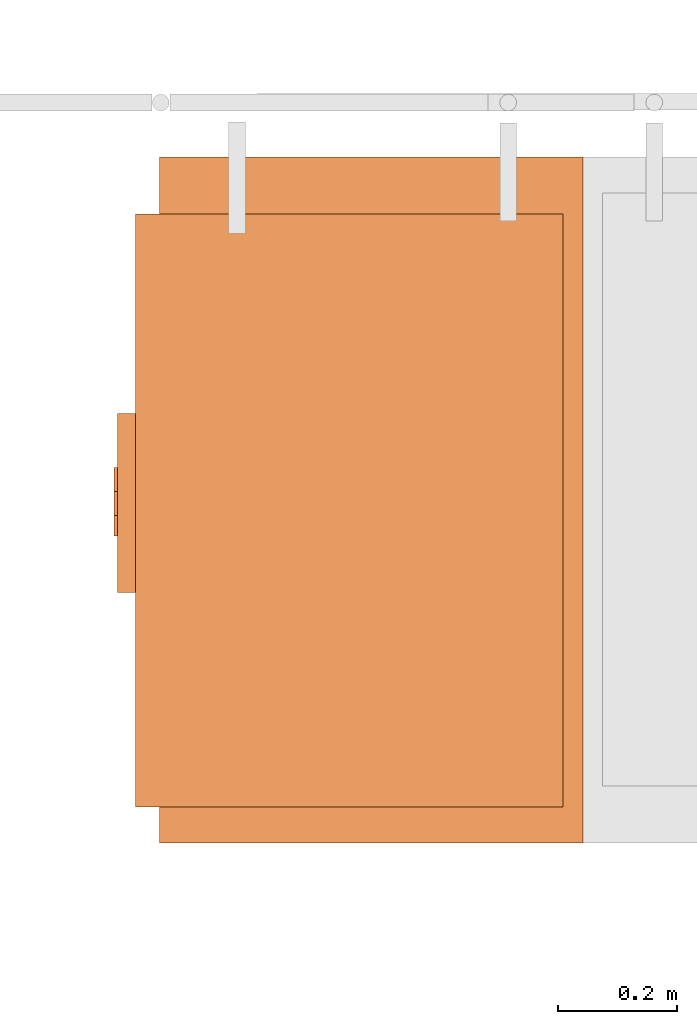
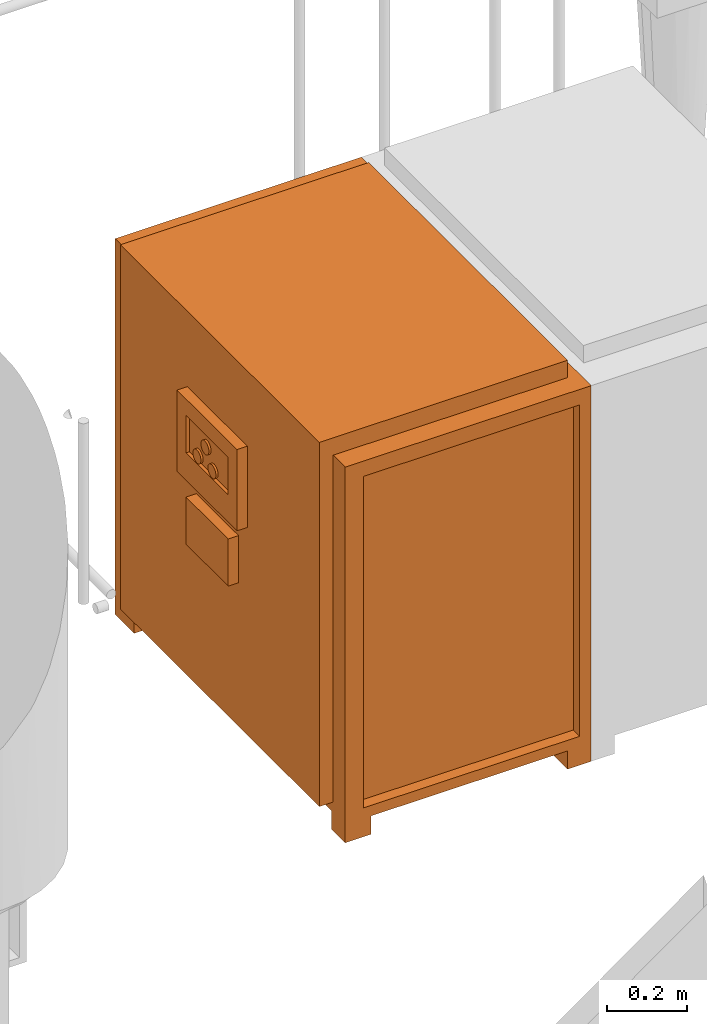
# One storey, part 327 of 331: 1 proxy.
"""IFC2X3 building model written with IfcOpenShell, lengths in millimetres."""

from ifc_helpers import new_model, entity, si_unit, converted_unit, derived_unit, direction, frame, origin, place, context, subcontext, project, spatial, faceted_brep, source, transform, mapped, material, material_list, type_object, type_shapes, element, save


model = new_model("IFC2X3")

# Units and contexts
model_context = context("Model", 3, precision=0.01, world=origin(), true_north=direction((6.12303176911189e-17, 1.0)))
body_context = subcontext(model_context, "Body", "Model", "MODEL_VIEW")
ifc_project = project(units=[si_unit("LENGTHUNIT", "METRE", prefix="MILLI"), si_unit("AREAUNIT", "SQUARE_METRE"), si_unit("VOLUMEUNIT", "CUBIC_METRE"), converted_unit("PLANEANGLEUNIT", "DEGREE", entity("IfcRatioMeasure", 0.0174532925199433), si_unit("PLANEANGLEUNIT", "RADIAN"), dimensions=[0, 0, 0, 0, 0, 0, 0]), si_unit("MASSUNIT", "GRAM", prefix="KILO"), derived_unit("MASSDENSITYUNIT", [(si_unit("MASSUNIT", "GRAM", prefix="KILO"), 1), (si_unit("LENGTHUNIT", "METRE"), -3)]), derived_unit("MOMENTOFINERTIAUNIT", [(si_unit("LENGTHUNIT", "METRE"), 4)]), si_unit("TIMEUNIT", "SECOND"), si_unit("FREQUENCYUNIT", "HERTZ"), si_unit("THERMODYNAMICTEMPERATUREUNIT", "DEGREE_CELSIUS"), derived_unit("THERMALTRANSMITTANCEUNIT", [(si_unit("MASSUNIT", "GRAM", prefix="KILO"), 1), (si_unit("THERMODYNAMICTEMPERATUREUNIT", "KELVIN"), -1), (si_unit("TIMEUNIT", "SECOND"), -3)]), derived_unit("VOLUMETRICFLOWRATEUNIT", [(si_unit("LENGTHUNIT", "METRE"), 3), (si_unit("TIMEUNIT", "SECOND"), -1)]), derived_unit("MASSFLOWRATEUNIT", [(si_unit("MASSUNIT", "GRAM", prefix="KILO"), 1), (si_unit("TIMEUNIT", "SECOND"), -1)]), derived_unit("ROTATIONALFREQUENCYUNIT", [(si_unit("TIMEUNIT", "SECOND"), -1)]), si_unit("ELECTRICCURRENTUNIT", "AMPERE"), si_unit("ELECTRICVOLTAGEUNIT", "VOLT"), si_unit("POWERUNIT", "WATT"), si_unit("FORCEUNIT", "NEWTON", prefix="KILO"), si_unit("ILLUMINANCEUNIT", "LUX"), si_unit("LUMINOUSFLUXUNIT", "LUMEN"), si_unit("LUMINOUSINTENSITYUNIT", "CANDELA"), derived_unit("USERDEFINED", [(si_unit("MASSUNIT", "GRAM", prefix="KILO"), -1), (si_unit("LENGTHUNIT", "METRE"), -2), (si_unit("TIMEUNIT", "SECOND"), 3), (si_unit("LUMINOUSFLUXUNIT", "LUMEN"), 1)]), derived_unit("LINEARVELOCITYUNIT", [(si_unit("LENGTHUNIT", "METRE"), 1), (si_unit("TIMEUNIT", "SECOND"), -1)]), si_unit("PRESSUREUNIT", "PASCAL"), derived_unit("USERDEFINED", [(si_unit("LENGTHUNIT", "METRE"), -2), (si_unit("MASSUNIT", "GRAM", prefix="KILO"), 1), (si_unit("TIMEUNIT", "SECOND"), -2)]), derived_unit("LINEARFORCEUNIT", [(si_unit("MASSUNIT", "GRAM", prefix="KILO"), 1), (si_unit("LENGTHUNIT", "METRE"), 1), (si_unit("TIMEUNIT", "SECOND"), -2), (si_unit("LENGTHUNIT", "METRE"), -1)]), derived_unit("PLANARFORCEUNIT", [(si_unit("MASSUNIT", "GRAM", prefix="KILO"), 1), (si_unit("LENGTHUNIT", "METRE"), 1), (si_unit("TIMEUNIT", "SECOND"), -2), (si_unit("LENGTHUNIT", "METRE"), -2)])], contexts=[model_context])

# Site, building, storey
site_placement = place(None, frame((0.0, -0.00077364408347762, 0.0)))
site = spatial("IfcSite", under=ifc_project, at=site_placement, CompositionType="ELEMENT")
building_placement = place(site_placement, origin())
building = spatial("IfcBuilding", under=site, at=building_placement, CompositionType="ELEMENT")
storey_placement = place(building_placement, origin())
storey = spatial("IfcBuildingStorey", under=building, at=storey_placement, CompositionType="ELEMENT", Elevation=0.0)

# Proxy
ifc_material_1 = material()
ifc_material_2 = material()
ifc_material_3 = material()
ifc_material_list = material_list([ifc_material_1, ifc_material_2, ifc_material_3])
building_element_proxy_type = type_object("IfcBuildingElementProxyType", Name="DC50:DC50", PredefinedType="NOTDEFINED", material=ifc_material_1)
shared_shape = source(origin(), body_context, "Body", "Brep", [
    faceted_brep([(-483.897349584665, 149.270597872865, 819.451035293873), (-483.897349584665, 145.128462249134, 822.629407745831), (-483.897349584665, 141.950089797176, 826.771543369562), (-483.897349584665, 139.952081347083, 831.595162467512), (-483.897349584665, 139.270597872864, 836.771543369562), (-483.897349584665, 139.952081347083, 841.947924271613), (-483.897349584665, 141.950089797176, 846.771543369562), (-483.897349584665, 145.128462249133, 850.913678993293), (-483.897349584665, 149.270597872864, 854.092051445251), (-483.897349584665, 154.094216970814, 856.090059895344), (-483.897349584665, 159.270597872864, 856.771543369562), (-483.897349584665, 164.446978774915, 856.090059895344), (-483.897349584665, 169.270597872864, 854.092051445251), (-483.897349584665, 173.412733496595, 850.913678993293), (-483.897349584665, 176.591105948553, 846.771543369562), (-483.897349584665, 178.589114398646, 841.947924271613), (-483.897349584665, 179.270597872864, 836.771543369562), (-483.897349584665, 178.589114398646, 831.595162467512), (-483.897349584665, 176.591105948553, 826.771543369562), (-483.897349584665, 173.412733496595, 822.629407745831), (-483.897349584665, 169.270597872865, 819.451035293873), (-483.897349584665, 164.446978774915, 817.453026843781), (-483.897349584665, 159.270597872865, 816.771543369562), (-483.897349584665, 154.094216970814, 817.453026843781), (-477.5, 164.446978774915, 856.090059895344), (-477.5, 159.270597872864, 856.771543369562), (-477.5, 154.094216970814, 856.090059895344), (-477.5, 149.270597872864, 854.092051445251), (-477.5, 145.128462249133, 850.913678993293), (-477.5, 141.950089797176, 846.771543369562), (-477.5, 139.952081347083, 841.947924271613), (-477.5, 139.270597872864, 836.771543369562), (-477.5, 139.952081347083, 831.595162467512), (-477.5, 141.950089797176, 826.771543369562), (-477.5, 145.128462249134, 822.629407745831), (-477.5, 149.270597872865, 819.451035293873), (-477.5, 154.094216970814, 817.453026843781), (-477.5, 159.270597872865, 816.771543369562), (-477.5, 164.446978774915, 817.453026843781), (-477.5, 169.270597872865, 819.451035293873), (-477.5, 173.412733496595, 822.629407745831), (-477.5, 176.591105948553, 826.771543369562), (-477.5, 178.589114398646, 831.595162467512), (-477.5, 179.270597872864, 836.771543369562), (-477.5, 178.589114398646, 841.947924271613), (-477.5, 176.591105948553, 846.771543369562), (-477.5, 173.412733496595, 850.913678993293), (-477.5, 169.270597872864, 854.092051445251)], [[[0, 1, 2, 3, 4, 5, 6, 7, 8, 9, 10, 11, 12, 13, 14, 15, 16, 17, 18, 19, 20, 21, 22, 23]], [[24, 25, 26, 27, 28, 29, 30, 31, 32, 33, 34, 35, 36, 37, 38, 39, 40, 41, 42, 43, 44, 45, 46, 47]], [[42, 17, 16, 43]], [[41, 18, 17, 42]], [[20, 19, 40, 39]], [[41, 40, 19, 18]], [[21, 20, 39, 38]], [[22, 21, 38, 37]], [[36, 23, 22, 37]], [[35, 0, 23, 36]], [[2, 1, 34, 33]], [[35, 34, 1, 0]], [[3, 2, 33, 32]], [[4, 3, 32, 31]], [[30, 5, 4, 31]], [[29, 6, 5, 30]], [[8, 7, 28, 27]], [[29, 28, 7, 6]], [[9, 8, 27, 26]], [[10, 9, 26, 25]], [[24, 11, 10, 25]], [[47, 12, 11, 24]], [[14, 13, 46, 45]], [[47, 46, 13, 12]], [[15, 14, 45, 44]], [[16, 15, 44, 43]]]),
    faceted_brep([(-483.897349584665, 224.270597872864, 819.451035293874), (-483.897349584665, 220.128462249133, 822.629407745831), (-483.897349584665, 216.950089797176, 826.771543369562), (-483.897349584665, 214.952081347083, 831.595162467512), (-483.897349584665, 214.270597872864, 836.771543369563), (-483.897349584665, 214.952081347083, 841.947924271613), (-483.897349584665, 216.950089797176, 846.771543369563), (-483.897349584665, 220.128462249133, 850.913678993294), (-483.897349584665, 224.270597872864, 854.092051445251), (-483.897349584665, 229.094216970814, 856.090059895344), (-483.897349584665, 234.270597872864, 856.771543369563), (-483.897349584665, 239.446978774915, 856.090059895344), (-483.897349584665, 244.270597872864, 854.092051445251), (-483.897349584665, 248.412733496595, 850.913678993294), (-483.897349584665, 251.591105948553, 846.771543369563), (-483.897349584665, 253.589114398646, 841.947924271613), (-483.897349584665, 254.270597872864, 836.771543369563), (-483.897349584665, 253.589114398646, 831.595162467512), (-483.897349584665, 251.591105948553, 826.771543369563), (-483.897349584665, 248.412733496595, 822.629407745832), (-483.897349584665, 244.270597872864, 819.451035293874), (-483.897349584665, 239.446978774915, 817.453026843781), (-483.897349584665, 234.270597872864, 816.771543369562), (-483.897349584665, 229.094216970814, 817.453026843781), (-477.5, 239.446978774915, 856.090059895344), (-477.5, 234.270597872864, 856.771543369563), (-477.5, 229.094216970814, 856.090059895344), (-477.5, 224.270597872864, 854.092051445251), (-477.5, 220.128462249133, 850.913678993294), (-477.5, 216.950089797176, 846.771543369563), (-477.5, 214.952081347083, 841.947924271613), (-477.5, 214.270597872864, 836.771543369562), (-477.5, 214.952081347083, 831.595162467512), (-477.5, 216.950089797176, 826.771543369562), (-477.5, 220.128462249133, 822.629407745831), (-477.5, 224.270597872864, 819.451035293874), (-477.5, 229.094216970814, 817.453026843781), (-477.5, 234.270597872864, 816.771543369562), (-477.5, 239.446978774915, 817.453026843781), (-477.5, 244.270597872864, 819.451035293874), (-477.5, 248.412733496595, 822.629407745832), (-477.5, 251.591105948553, 826.771543369563), (-477.5, 253.589114398646, 831.595162467512), (-477.5, 254.270597872864, 836.771543369563), (-477.5, 253.589114398646, 841.947924271613), (-477.5, 251.591105948553, 846.771543369563), (-477.5, 248.412733496595, 850.913678993294), (-477.5, 244.270597872864, 854.092051445251)], [[[0, 1, 2, 3, 4, 5, 6, 7, 8, 9, 10, 11, 12, 13, 14, 15, 16, 17, 18, 19, 20, 21, 22, 23]], [[24, 25, 26, 27, 28, 29, 30, 31, 32, 33, 34, 35, 36, 37, 38, 39, 40, 41, 42, 43, 44, 45, 46, 47]], [[42, 17, 16, 43]], [[41, 18, 17, 42]], [[20, 19, 40, 39]], [[41, 40, 19, 18]], [[21, 20, 39, 38]], [[22, 21, 38, 37]], [[36, 23, 22, 37]], [[35, 0, 23, 36]], [[2, 1, 34, 33]], [[35, 34, 1, 0]], [[3, 2, 33, 32]], [[4, 3, 32, 31]], [[30, 5, 4, 31]], [[29, 6, 5, 30]], [[8, 7, 28, 27]], [[29, 28, 7, 6]], [[9, 8, 27, 26]], [[10, 9, 26, 25]], [[24, 11, 10, 25]], [[47, 12, 11, 24]], [[14, 13, 46, 45]], [[47, 46, 13, 12]], [[15, 14, 45, 44]], [[16, 15, 44, 43]]]),
    faceted_brep([(-483.897349584665, 184.252601976697, 870.671734278311), (-483.897349584665, 180.110466352966, 873.850106730268), (-483.897349584665, 176.932093901008, 877.992242353999), (-483.897349584665, 174.934085450915, 882.815861451949), (-483.897349584665, 174.252601976696, 887.992242353999), (-483.897349584665, 174.934085450915, 893.16862325605), (-483.897349584665, 176.932093901008, 897.992242353999), (-483.897349584665, 180.110466352965, 902.13437797773), (-483.897349584665, 184.252601976696, 905.312750429688), (-483.897349584665, 189.076221074646, 907.310758879781), (-483.897349584665, 194.252601976696, 907.992242353999), (-483.897349584665, 199.428982878747, 907.310758879781), (-483.897349584665, 204.252601976696, 905.312750429688), (-483.897349584665, 208.394737600427, 902.13437797773), (-483.897349584665, 211.573110052385, 897.992242353999), (-483.897349584665, 213.571118502478, 893.16862325605), (-483.897349584665, 214.252601976696, 887.992242353999), (-483.897349584665, 213.571118502478, 882.815861451949), (-483.897349584665, 211.573110052385, 877.992242354), (-483.897349584665, 208.394737600427, 873.850106730269), (-483.897349584665, 204.252601976697, 870.671734278311), (-483.897349584665, 199.428982878747, 868.673725828218), (-483.897349584665, 194.252601976697, 867.992242353999), (-483.897349584665, 189.076221074646, 868.673725828218), (-477.5, 199.428982878747, 907.310758879781), (-477.5, 194.252601976696, 907.992242353999), (-477.5, 189.076221074646, 907.310758879781), (-477.5, 184.252601976696, 905.312750429688), (-477.5, 180.110466352965, 902.13437797773), (-477.5, 176.932093901008, 897.992242353999), (-477.5, 174.934085450915, 893.16862325605), (-477.5, 174.252601976696, 887.992242353999), (-477.5, 174.934085450915, 882.815861451949), (-477.5, 176.932093901008, 877.992242353999), (-477.5, 180.110466352966, 873.850106730268), (-477.5, 184.252601976697, 870.671734278311), (-477.5, 189.076221074646, 868.673725828218), (-477.5, 194.252601976697, 867.992242353999), (-477.5, 199.428982878747, 868.673725828218), (-477.5, 204.252601976697, 870.671734278311), (-477.5, 208.394737600427, 873.850106730269), (-477.5, 211.573110052385, 877.992242354), (-477.5, 213.571118502478, 882.815861451949), (-477.5, 214.252601976696, 887.992242353999), (-477.5, 213.571118502478, 893.16862325605), (-477.5, 211.573110052385, 897.992242353999), (-477.5, 208.394737600427, 902.13437797773), (-477.5, 204.252601976696, 905.312750429688)], [[[0, 1, 2, 3, 4, 5, 6, 7, 8, 9, 10, 11, 12, 13, 14, 15, 16, 17, 18, 19, 20, 21, 22, 23]], [[24, 25, 26, 27, 28, 29, 30, 31, 32, 33, 34, 35, 36, 37, 38, 39, 40, 41, 42, 43, 44, 45, 46, 47]], [[42, 17, 16, 43]], [[41, 18, 17, 42]], [[20, 19, 40, 39]], [[41, 40, 19, 18]], [[21, 20, 39, 38]], [[22, 21, 38, 37]], [[36, 23, 22, 37]], [[35, 0, 23, 36]], [[2, 1, 34, 33]], [[35, 34, 1, 0]], [[3, 2, 33, 32]], [[4, 3, 32, 31]], [[30, 5, 4, 31]], [[29, 6, 5, 30]], [[8, 7, 28, 27]], [[29, 28, 7, 6]], [[9, 8, 27, 26]], [[10, 9, 26, 25]], [[24, 11, 10, 25]], [[47, 12, 11, 24]], [[14, 13, 46, 45]], [[47, 46, 13, 12]], [[15, 14, 45, 44]], [[16, 15, 44, 43]]]),
    faceted_brep([(-477.500000000001, 300.0, 670.684385919393), (-477.500000000002, 88.5891967833818, 670.684385919393), (-447.500000000001, 88.5891967833817, 670.684385919393), (-447.500000000001, 300.0, 670.684385919393), (-477.500000000001, 300.0, 527.078251788917), (-447.500000000001, 300.0, 527.078251788917), (-447.500000000001, 88.5891967833817, 527.078251788917), (-477.500000000002, 88.5891967833818, 527.078251788917)], [[[0, 1, 2, 3]], [[4, 5, 6, 7]], [[1, 0, 4, 7]], [[2, 1, 7, 6]], [[3, 2, 6, 5]], [[0, 3, 5, 4]]]),
    faceted_brep([(-407.500000000004, 680.0, 1146.89219153294), (302.832876680296, 680.0, 1146.89219153294), (302.832876680296, 775.106496329684, 1146.89219153294), (-407.500000000003, 775.106496329686, 1146.89219153294), (302.832876680296, 775.106496329684, 0.0), (302.832876680296, 680.0, 0.0), (234.287667008801, 680.0, 0.0), (234.287667008801, 775.106496329684, 0.0), (-407.500000000004, 680.0, 0.0), (-332.499999999999, 680.0, 0.0), (-332.499999999999, 680.0, 56.089418150774), (234.287667008801, 680.0, 56.089418150774), (234.287667008802, 775.106496329684, 56.089418150774), (-332.499999999999, 775.106496329686, 56.089418150774), (-332.499999999999, 775.106496329686, 0.0), (-407.500000000003, 775.106496329686, 0.0)], [[[0, 1, 2, 3]], [[4, 5, 6, 7]], [[1, 0, 8, 9, 10, 11, 6, 5]], [[2, 1, 5, 4]], [[3, 2, 4, 7, 12, 13, 14, 15]], [[0, 3, 15, 8]], [[13, 10, 9, 14]], [[11, 12, 7, 6]], [[12, 11, 10, 13]], [[8, 15, 14, 9]]]),
    faceted_brep([(-477.500000000001, 345.0, 970.0), (-477.500000000002, 45.0, 970.0), (-447.500000000001, 45.0, 970.0), (-447.500000000001, 345.0, 970.0), (-477.500000000001, 345.0, 722.191638385122), (-447.500000000001, 345.0, 722.191638385122), (-447.500000000001, 45.0, 722.191638385122), (-477.500000000002, 45.0, 722.191638385122), (-477.500000000001, 300.0, 920.0), (-477.500000000002, 88.5891967833821, 920.0), (-477.500000000002, 88.589196783382, 805.330017864731), (-477.500000000001, 300.0, 805.330017864731), (-467.5, 88.589196783382, 920.0), (-467.5, 300.0, 920.0), (-467.5, 300.0, 805.330017864731), (-467.5, 88.589196783382, 805.330017864731)], [[[0, 1, 2, 3]], [[4, 5, 6, 7]], [[1, 0, 4, 7], [8, 9, 10, 11]], [[2, 1, 7, 6]], [[3, 2, 6, 5]], [[0, 3, 5, 4]], [[12, 13, 14, 15]], [[13, 12, 9, 8]], [[14, 13, 8, 11]], [[15, 14, 11, 10]], [[12, 15, 10, 9]]]),
    faceted_brep([(-407.500000000001, -375.0, 1146.89219153294), (302.832876680294, -375.0, 1146.89219153294), (302.832876680296, 680.0, 1146.89219153294), (-407.5, 680.0, 1146.89219153294), (302.832876680295, -305.288454892349, 0.0), (302.832876680294, -375.0, 0.0), (234.2876670088, -375.0, 0.0), (234.2876670088, -305.288454892349, 0.0), (-407.500000000001, -375.0, 0.0), (-332.500000000001, -375.0, 0.0), (-332.500000000001, -375.0, 56.089418150774), (234.2876670088, -375.0, 56.089418150774), (-355.365527080025, -375.0, 1100.0), (269.430307946747, -375.0, 1100.0), (269.430307946745, -375.0, 88.1437175093121), (-355.365527080026, -375.0, 88.1437175093141), (302.832876680295, -305.288454892349, 56.089418150774), (302.832876680296, 680.0, 56.089418150774), (-407.5, 680.0, 56.089418150774), (-407.500000000001, -305.288454892346, 56.089418150774), (-407.500000000001, -305.288454892346, 0.0), (269.430307946747, -342.939909824343, 1100.0), (-355.365527080025, -342.939909824343, 1100.0), (-355.365527080026, -342.939909824343, 88.1437175093141), (269.430307946745, -342.939909824343, 88.1437175093121), (234.2876670088, -305.288454892349, 56.089418150774), (-332.500000000001, -305.288454892347, 56.089418150774), (-332.500000000001, -305.288454892347, 0.0)], [[[0, 1, 2, 3]], [[4, 5, 6, 7]], [[1, 0, 8, 9, 10, 11, 6, 5], [12, 13, 14, 15]], [[2, 1, 5, 4, 16, 17]], [[3, 2, 17, 18]], [[0, 3, 18, 19, 20, 8]], [[21, 22, 23, 24]], [[22, 21, 13, 12]], [[23, 22, 12, 15]], [[24, 23, 15, 14]], [[21, 24, 14, 13]], [[17, 16, 25, 11, 10, 26, 19, 18]], [[20, 19, 26, 27]], [[26, 10, 9, 27]], [[11, 25, 7, 6]], [[16, 4, 7, 25]], [[8, 20, 27, 9]]]),
    faceted_brep([(269.43030794675, 680.0, 1199.899117756), (-447.5, 680.0, 1199.899117756), (-447.500000000001, -315.0, 1199.899117756), (269.430307946746, -315.0, 1199.899117756), (269.43030794675, 680.0, 88.1437175093128), (269.430307946746, -315.0, 88.1437175093128), (-447.500000000001, -315.0, 88.1437175093128), (-447.499999999999, 680.0, 88.1437175093128)], [[[0, 1, 2, 3]], [[4, 5, 6, 7]], [[1, 0, 4, 7]], [[2, 1, 7, 6]], [[3, 2, 6, 5]], [[0, 3, 5, 4]]]),
])
type_shapes(building_element_proxy_type, [shared_shape])
proxy_placement = place(storey_placement, frame((52077.5036168841, -1555.00010169854, -700.0)))
element("IfcBuildingElementProxy", 1, at=proxy_placement, inside=storey, type_object=building_element_proxy_type, material=ifc_material_list, Name="DC50:DC50", ObjectType="DC50:DC50", context=body_context, shape_type="MappedRepresentation", body=[
    mapped(shared_shape, transform((0.0, 0.0, 0.0), scale=1.0)),
])

save(model, "model.ifc")
